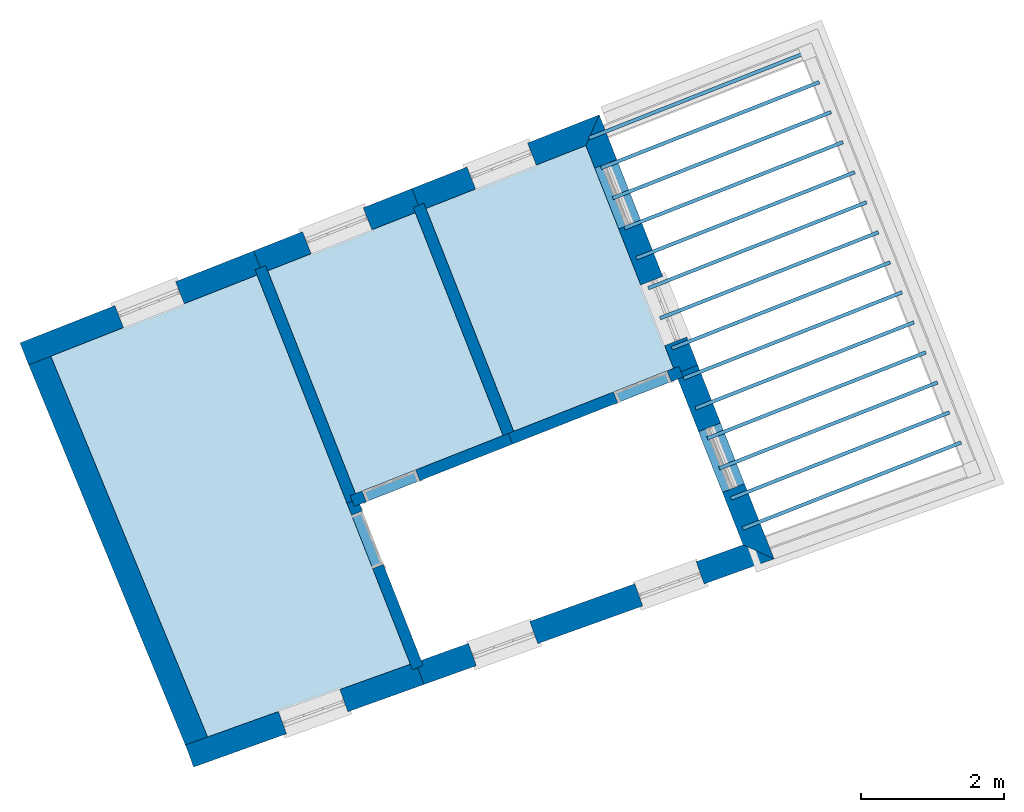
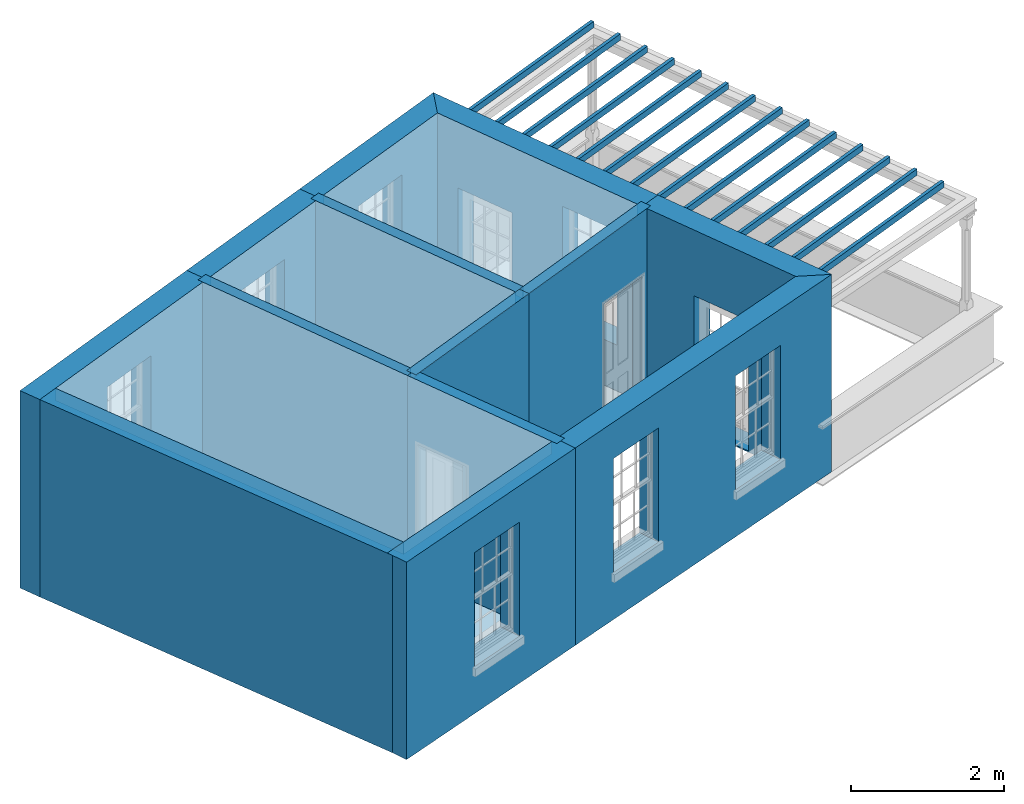
# One storey, part 1 of 8: 20 slabs, 13 walls, 12 openings.
"""IFC2X3 building model written with IfcOpenShell, lengths in metres."""

from ifc_helpers import new_model, si_unit, frame, origin, place, context, subcontext, project, spatial, polyline, outline, extrude, material, layer, layer_set, layer_usage, element, save


model = new_model("IFC2X3")

# Units and contexts
model_context = context("Model", 3, world=origin())
body_context = subcontext(model_context, "Body", "Model", "MODEL_VIEW")
ifc_project = project(units=[si_unit("PLANEANGLEUNIT", "RADIAN"), si_unit("MASSUNIT", "GRAM", prefix="KILO"), si_unit("FORCEUNIT", "NEWTON", prefix="KILO"), si_unit("LENGTHUNIT", "METRE")], contexts=[model_context])

# Site, building, storey
site_placement = place(None, origin())
site = spatial("IfcSite", under=ifc_project, at=site_placement, CompositionType="ELEMENT")
building_placement = place(None, origin())
building = spatial("IfcBuilding", under=site, at=building_placement, Name="Building plot-4", CompositionType="ELEMENT")
storey_placement = place(None, frame((0.0, 0.0, 9.45)))
storey = spatial("IfcBuildingStorey", under=building, at=storey_placement, Name="Floor 2", CompositionType="ELEMENT", Elevation=9.45)

# Slabs
slab_1_placement = place(storey_placement, frame((0.0, 0.0, 2.95)))
element("IfcSlab", 1, at=slab_1_placement, inside=storey, Name="Slab", ObjectType="Slab", PredefinedType="FLOOR", context=body_context, shape_type="SweptSolid", body=[
    extrude(outline(polyline([(47.3779728153786, 51.938533144609), (44.502052775966, 50.8059380590818), (46.6888976082681, 45.4977503358858), (49.5151493068038, 46.5117493116291), (47.3779728153786, 51.938533144609)])), origin(), (0.0, 0.0, 1.0), 0.2),
])
slab_2_placement = place(storey_placement, frame((0.0, 0.0, 2.95)))
element("IfcSlab", 2, at=slab_2_placement, inside=storey, Name="Slab", ObjectType="Slab", PredefinedType="FLOOR", context=body_context, shape_type="SweptSolid", body=[
    extrude(outline(polyline([(50.9563121382697, 49.7590058579402), (53.185811513538, 50.6370275000616), (51.9622563685918, 53.743916100977), (49.7327569933235, 52.8658944588556), (50.9563121382697, 49.7590058579402)])), origin(), (0.0, 0.0, 1.0), 0.2),
])
slab_3_placement = place(storey_placement, frame((0.0, 0.0, 2.65)))
element("IfcSlab", 3, at=slab_3_placement, inside=storey, Name="Slab", ObjectType="Slab", PredefinedType="FLOOR", context=body_context, shape_type="SweptSolid", body=[
    extrude(outline(polyline([(51.9982170837161, 53.8709272302836), (52.0165385048251, 53.8244049181254), (55.0610735768132, 55.0234039907677), (55.0427521557042, 55.0699263029259), (51.9982170837161, 53.8709272302836)])), origin(), (0.0, 0.0, 1.0), 0.1),
])
slab_4_placement = place(storey_placement, frame((0.0, 0.0, 2.65)))
element("IfcSlab", 4, at=slab_4_placement, inside=storey, Name="Slab", ObjectType="Slab", PredefinedType="FLOOR", context=body_context, shape_type="SweptSolid", body=[
    extrude(outline(polyline([(52.1631098736968, 53.4522264208595), (52.1814312948057, 53.4057041087013), (55.2259663667938, 54.6047031813436), (55.2076449456849, 54.6512254935018), (52.1631098736968, 53.4522264208595)])), origin(), (0.0, 0.0, 1.0), 0.1),
])
slab_5_placement = place(storey_placement, frame((0.0, 0.0, 2.65)))
element("IfcSlab", 5, at=slab_5_placement, inside=storey, Name="Slab", ObjectType="Slab", PredefinedType="FLOOR", context=body_context, shape_type="SweptSolid", body=[
    extrude(outline(polyline([(52.3280026636774, 53.0335256114354), (52.3463240847864, 52.9870032992772), (55.3908591567745, 54.1860023719195), (55.3725377356655, 54.2325246840777), (52.3280026636774, 53.0335256114354)])), origin(), (0.0, 0.0, 1.0), 0.1),
])
slab_6_placement = place(storey_placement, frame((0.0, 0.0, 2.65)))
element("IfcSlab", 6, at=slab_6_placement, inside=storey, Name="Slab", ObjectType="Slab", PredefinedType="FLOOR", context=body_context, shape_type="SweptSolid", body=[
    extrude(outline(polyline([(52.4928954536581, 52.6148248020113), (52.511216874767, 52.5683024898531), (55.5557519467552, 53.7673015624954), (55.5374305256462, 53.8138238746536), (52.4928954536581, 52.6148248020113)])), origin(), (0.0, 0.0, 1.0), 0.1),
])
slab_7_placement = place(storey_placement, frame((0.0, 0.0, 2.65)))
element("IfcSlab", 7, at=slab_7_placement, inside=storey, Name="Slab", ObjectType="Slab", PredefinedType="FLOOR", context=body_context, shape_type="SweptSolid", body=[
    extrude(outline(polyline([(52.6577882436387, 52.1961239925872), (52.6761096647477, 52.149601680429), (55.7206447367358, 53.3486007530713), (55.7023233156268, 53.3951230652295), (52.6577882436387, 52.1961239925872)])), origin(), (0.0, 0.0, 1.0), 0.1),
])
slab_8_placement = place(storey_placement, frame((0.0, 0.0, 2.65)))
element("IfcSlab", 8, at=slab_8_placement, inside=storey, Name="Slab", ObjectType="Slab", PredefinedType="FLOOR", context=body_context, shape_type="SweptSolid", body=[
    extrude(outline(polyline([(52.8226810336194, 51.7774231831631), (52.8410024547284, 51.7309008710049), (55.8855375267165, 52.9298999436472), (55.8672161056075, 52.9764222558054), (52.8226810336194, 51.7774231831631)])), origin(), (0.0, 0.0, 1.0), 0.1),
])
slab_9_placement = place(storey_placement, frame((0.0, 0.0, 2.65)))
element("IfcSlab", 9, at=slab_9_placement, inside=storey, Name="Slab", ObjectType="Slab", PredefinedType="FLOOR", context=body_context, shape_type="SweptSolid", body=[
    extrude(outline(polyline([(52.9875738236, 51.358722373739), (53.005895244709, 51.3122000615808), (56.0504303166971, 52.5111991342231), (56.0321088955882, 52.5577214463813), (52.9875738236, 51.358722373739)])), origin(), (0.0, 0.0, 1.0), 0.1),
])
slab_10_placement = place(storey_placement, frame((0.0, 0.0, 2.65)))
element("IfcSlab", 10, at=slab_10_placement, inside=storey, Name="Slab", ObjectType="Slab", PredefinedType="FLOOR", context=body_context, shape_type="SweptSolid", body=[
    extrude(outline(polyline([(53.1524666135807, 50.9400215643149), (53.1707880346897, 50.8934992521567), (56.2153231066778, 52.092498324799), (56.1970016855688, 52.1390206369572), (53.1524666135807, 50.9400215643149)])), origin(), (0.0, 0.0, 1.0), 0.1),
])
slab_11_placement = place(storey_placement, frame((0.0, 0.0, 2.65)))
element("IfcSlab", 11, at=slab_11_placement, inside=storey, Name="Slab", ObjectType="Slab", PredefinedType="FLOOR", context=body_context, shape_type="SweptSolid", body=[
    extrude(outline(polyline([(53.3173594035614, 50.5213207548908), (53.3356808246703, 50.4747984427326), (56.3802158966584, 51.6737975153749), (56.3618944755495, 51.7203198275331), (53.3173594035614, 50.5213207548908)])), origin(), (0.0, 0.0, 1.0), 0.1),
])
slab_12_placement = place(storey_placement, frame((0.0, 0.0, 2.65)))
element("IfcSlab", 12, at=slab_12_placement, inside=storey, Name="Slab", ObjectType="Slab", PredefinedType="FLOOR", context=body_context, shape_type="SweptSolid", body=[
    extrude(outline(polyline([(53.482252193542, 50.1026199454667), (53.500573614651, 50.0560976333085), (56.5451086866391, 51.2550967059508), (56.5267872655301, 51.301619018109), (53.482252193542, 50.1026199454667)])), origin(), (0.0, 0.0, 1.0), 0.1),
])
slab_13_placement = place(storey_placement, frame((0.0, 0.0, 2.65)))
element("IfcSlab", 13, at=slab_13_placement, inside=storey, Name="Slab", ObjectType="Slab", PredefinedType="FLOOR", context=body_context, shape_type="SweptSolid", body=[
    extrude(outline(polyline([(53.6471449835227, 49.6839191360426), (53.6654664046316, 49.6373968238844), (56.7100014766198, 50.8363958965267), (56.6916800555108, 50.8829182086849), (53.6471449835227, 49.6839191360426)])), origin(), (0.0, 0.0, 1.0), 0.1),
])
slab_14_placement = place(storey_placement, frame((0.0, 0.0, 2.65)))
element("IfcSlab", 14, at=slab_14_placement, inside=storey, Name="Slab", ObjectType="Slab", PredefinedType="FLOOR", context=body_context, shape_type="SweptSolid", body=[
    extrude(outline(polyline([(53.8120377735033, 49.2652183266185), (53.8303591946123, 49.2186960144603), (56.8748942666004, 50.4176950871026), (56.8565728454914, 50.4642173992608), (53.8120377735033, 49.2652183266185)])), origin(), (0.0, 0.0, 1.0), 0.1),
])
slab_15_placement = place(storey_placement, frame((0.0, 0.0, 2.65)))
element("IfcSlab", 15, at=slab_15_placement, inside=storey, Name="Slab", ObjectType="Slab", PredefinedType="FLOOR", context=body_context, shape_type="SweptSolid", body=[
    extrude(outline(polyline([(53.976930563484, 48.8465175171944), (53.9952519845929, 48.7999952050362), (57.0397870565811, 49.9989942776785), (57.0214656354721, 50.0455165898367), (53.976930563484, 48.8465175171944)])), origin(), (0.0, 0.0, 1.0), 0.1),
])
slab_16_placement = place(storey_placement, frame((0.0, 0.0, 2.65)))
element("IfcSlab", 16, at=slab_16_placement, inside=storey, Name="Slab", ObjectType="Slab", PredefinedType="FLOOR", context=body_context, shape_type="SweptSolid", body=[
    extrude(outline(polyline([(54.1418233534646, 48.4278167077703), (54.1601447745736, 48.3812943956121), (57.2046798465617, 49.5802934682544), (57.1863584254528, 49.6268157804126), (54.1418233534646, 48.4278167077703)])), origin(), (0.0, 0.0, 1.0), 0.1),
])
slab_17_placement = place(storey_placement, frame((0.0, 0.0, 2.95)))
element("IfcSlab", 17, at=slab_17_placement, inside=storey, Name="Slab", ObjectType="Slab", PredefinedType="FLOOR", context=body_context, shape_type="SweptSolid", body=[
    extrude(outline(polyline([(48.7503993592311, 48.8902730912423), (50.8074407393634, 49.7003773103915), (49.5838855944172, 52.8072659113069), (47.5268442142849, 51.9971616921577), (48.7503993592311, 48.8902730912423)])), origin(), (0.0, 0.0, 1.0), 0.2),
])
slab_18_placement = place(storey_placement, origin())
element("IfcSlab", 18, at=slab_18_placement, inside=storey, Name="Slab", ObjectType="Slab", PredefinedType="FLOOR", context=body_context, shape_type="SweptSolid", body=[
    extrude(outline(polyline([(47.3779728153786, 51.938533144609), (44.502052775966, 50.8059380590818), (46.6888976082681, 45.4977503358858), (49.5151493068038, 46.5117493116291), (47.3779728153786, 51.938533144609)])), origin(), (0.0, 0.0, 1.0), 0.02),
])
slab_19_placement = place(storey_placement, origin())
element("IfcSlab", 19, at=slab_19_placement, inside=storey, Name="Slab", ObjectType="Slab", PredefinedType="FLOOR", context=body_context, shape_type="SweptSolid", body=[
    extrude(outline(polyline([(50.9563121382697, 49.7590058579402), (53.185811513538, 50.6370275000616), (51.9622563685918, 53.743916100977), (49.7327569933235, 52.8658944588556), (50.9563121382697, 49.7590058579402)])), origin(), (0.0, 0.0, 1.0), 0.02),
])
slab_20_placement = place(storey_placement, origin())
element("IfcSlab", 20, at=slab_20_placement, inside=storey, Name="Slab", ObjectType="Slab", PredefinedType="FLOOR", context=body_context, shape_type="SweptSolid", body=[
    extrude(outline(polyline([(48.7503993592311, 48.8902730912423), (50.8074407393634, 49.7003773103915), (49.5838855944172, 52.8072659113069), (47.5268442142849, 51.9971616921577), (48.7503993592311, 48.8902730912423)])), origin(), (0.0, 0.0, 1.0), 0.02),
])

# Wall, opening
ifc_material_1 = material(Name="Masonry")
ifc_layer_1 = layer(ifc_material_1, 0.33, ventilated=False)
ifc_layer_set_1 = layer_set([ifc_layer_1], Name="My Wall")
ifc_layer_usage_1 = layer_usage(ifc_layer_set_1, "AXIS2", "NEGATIVE", 0.08)
wall_1_placement = place(storey_placement, origin())
wall_1 = element("IfcWallStandardCase", 21, at=wall_1_placement, inside=storey, material=ifc_layer_usage_1, Name="exterior", context=body_context, shape_type="SweptSolid", body=[
    extrude(outline(polyline([(46.3816931332496, 45.3875319065881), (46.4931346698559, 45.0769183461649), (49.70423854185, 46.2289940933087), (49.5927970052436, 46.539607653732), (46.3816931332496, 45.3875319065881)])), origin(), (0.0, 0.0, 1.0), 3.15),
])
opening_1_placement = place(storey_placement, frame((0.0, 0.0, 0.75)))
element("IfcOpeningElement", 22, at=opening_1_placement, cuts=wall_1, Name="Opening", ObjectType="Opening", context=body_context, shape_type="SweptSolid", body=[
    extrude(outline(polyline([(47.7880730454297, 45.5415146831305), (48.6446134696272, 45.8488231628631), (48.5331719330208, 46.1594367232864), (47.6766315088233, 45.8521282435537), (47.7880730454297, 45.5415146831305)])), origin(), (0.0, 0.0, 1.0), 1.82),
])

# Wall, openings
wall_2_placement = place(storey_placement, origin())
wall_2 = element("IfcWallStandardCase", 23, at=wall_2_placement, inside=storey, material=ifc_layer_usage_1, Name="exterior", context=body_context, shape_type="SweptSolid", body=[
    extrude(outline(polyline([(49.5927970052436, 46.539607653732), (49.70423854185, 46.2289940933087), (54.5866021542831, 47.9806822762042), (54.1548638616126, 48.176380175453), (49.5927970052436, 46.539607653732)])), origin(), (0.0, 0.0, 1.0), 3.15),
])
opening_2_placement = place(storey_placement, frame((0.0, 0.0, 0.75)))
element("IfcOpeningElement", 24, at=opening_2_placement, cuts=wall_2, Name="Opening", ObjectType="Opening", context=body_context, shape_type="SweptSolid", body=[
    extrude(outline(polyline([(50.4358969684534, 46.4914975693984), (51.2924373926509, 46.7988060491311), (51.1809958560445, 47.1094196095543), (50.3244554318471, 46.8021111298216), (50.4358969684534, 46.4914975693984)])), origin(), (0.0, 0.0, 1.0), 1.82),
])
opening_3_placement = place(storey_placement, frame((0.0, 0.0, 0.75)))
element("IfcOpeningElement", 25, at=opening_3_placement, cuts=wall_2, Name="Opening", ObjectType="Opening", context=body_context, shape_type="SweptSolid", body=[
    extrude(outline(polyline([(52.7557542458578, 47.3238130013103), (53.6122946700553, 47.631121481043), (53.5008531334489, 47.9417350414663), (52.6443127092515, 47.6344265617336), (52.7557542458578, 47.3238130013103)])), origin(), (0.0, 0.0, 1.0), 1.82),
])

# Wall, opening
wall_3_placement = place(storey_placement, origin())
wall_3 = element("IfcWallStandardCase", 26, at=wall_3_placement, inside=storey, material=ifc_layer_usage_1, Name="exterior", context=body_context, shape_type="SweptSolid", body=[
    extrude(outline(polyline([(54.1548638616126, 48.176380175453), (54.5866021542831, 47.9806822762042), (53.5221730475567, 50.6835131799276), (53.2151257873123, 50.5625918006085), (54.1548638616126, 48.176380175453)])), origin(), (0.0, 0.0, 1.0), 3.15),
])
opening_4_placement = place(storey_placement, frame((0.0, 0.0, 0.0199999999999996)))
element("IfcOpeningElement", 27, at=opening_4_placement, cuts=wall_3, Name="Opening", ObjectType="Opening", context=body_context, shape_type="SweptSolid", body=[
    extrude(outline(polyline([(54.1738810813349, 49.0286762323381), (53.8404312171518, 49.8753823136179), (53.5333839569074, 49.7544609342988), (53.8668338210905, 48.9077548530189), (54.1738810813349, 49.0286762323381)])), origin(), (0.0, 0.0, 1.0), 2.08),
])

# Wall, openings
wall_4_placement = place(storey_placement, origin())
wall_4 = element("IfcWallStandardCase", 28, at=wall_4_placement, inside=storey, material=ifc_layer_usage_1, Name="exterior", context=body_context, shape_type="SweptSolid", body=[
    extrude(outline(polyline([(53.2151257873123, 50.5625918006085), (53.5221730475567, 50.6835131799276), (52.148382249517, 54.1718847405405), (51.9622563685918, 53.743916100977), (53.2151257873123, 50.5625918006085)])), origin(), (0.0, 0.0, 1.0), 3.15),
])
opening_5_placement = place(storey_placement, frame((0.0, 0.0, 0.75)))
element("IfcOpeningElement", 29, at=opening_5_placement, cuts=wall_4, Name="Opening", ObjectType="Opening", context=body_context, shape_type="SweptSolid", body=[
    extrude(outline(polyline([(53.3683520565245, 51.0741001392431), (53.0349021923414, 51.9208062205229), (52.7278549320971, 51.7998848412038), (53.0613047962801, 50.953178759924), (53.3683520565245, 51.0741001392431)])), origin(), (0.0, 0.0, 1.0), 1.82),
])
opening_6_placement = place(storey_placement, frame((0.0, 0.0, 0.0199999999999996)))
element("IfcOpeningElement", 30, at=opening_6_placement, cuts=wall_4, Name="Opening", ObjectType="Opening", context=body_context, shape_type="SweptSolid", body=[
    extrude(outline(polyline([(52.727260210277, 52.701980139154), (52.393810346094, 53.5486862204338), (52.0867630858496, 53.4277648411147), (52.4202129500327, 52.5810587598348), (52.727260210277, 52.701980139154)])), origin(), (0.0, 0.0, 1.0), 2.08),
])

# Wall, opening
wall_5_placement = place(storey_placement, origin())
wall_5 = element("IfcWallStandardCase", 31, at=wall_5_placement, inside=storey, material=ifc_layer_usage_1, Name="exterior", context=body_context, shape_type="SweptSolid", body=[
    extrude(outline(polyline([(51.9622563685918, 53.743916100977), (52.148382249517, 54.1718847405405), (49.5373999145512, 53.1436274453256), (49.6583212938703, 52.8365801850812), (51.9622563685918, 53.743916100977)])), origin(), (0.0, 0.0, 1.0), 3.15),
])
opening_7_placement = place(storey_placement, frame((0.0, 0.0, 0.75)))
element("IfcOpeningElement", 32, at=opening_7_placement, cuts=wall_5, Name="Opening", ObjectType="Opening", context=body_context, shape_type="SweptSolid", body=[
    extrude(outline(polyline([(51.1499383422784, 53.7786774722522), (50.3032322609986, 53.4452276080691), (50.4241536403177, 53.1381803478247), (51.2708597215976, 53.4716302120078), (51.1499383422784, 53.7786774722522)])), origin(), (0.0, 0.0, 1.0), 1.82),
])

wall_6_placement = place(storey_placement, origin())
wall_6 = element("IfcWallStandardCase", 33, at=wall_6_placement, inside=storey, material=ifc_layer_usage_1, Name="exterior", context=body_context, shape_type="SweptSolid", body=[
    extrude(outline(polyline([(49.6583212938703, 52.8365801850812), (49.5373999145512, 53.1436274453256), (47.3314871355126, 52.2748946786277), (47.4524085148317, 51.9678474183833), (49.6583212938703, 52.8365801850812)])), origin(), (0.0, 0.0, 1.0), 3.15),
])
opening_8_placement = place(storey_placement, frame((0.0, 0.0, 0.75)))
element("IfcOpeningElement", 34, at=opening_8_placement, cuts=wall_6, Name="Opening", ObjectType="Opening", context=body_context, shape_type="SweptSolid", body=[
    extrude(outline(polyline([(48.8577965656718, 52.8759859940682), (48.011090484392, 52.5425361298851), (48.1320118637111, 52.2354888696407), (48.978717944991, 52.5689387338238), (48.8577965656718, 52.8759859940682)])), origin(), (0.0, 0.0, 1.0), 1.82),
])

wall_7_placement = place(storey_placement, origin())
wall_7 = element("IfcWallStandardCase", 35, at=wall_7_placement, inside=storey, material=ifc_layer_usage_1, Name="exterior", context=body_context, shape_type="SweptSolid", body=[
    extrude(outline(polyline([(47.4524085148317, 51.9678474183833), (47.3314871355126, 52.2748946786277), (44.0729122767796, 50.9916024381462), (44.1938336560988, 50.6845551779018), (47.4524085148317, 51.9678474183833)])), origin(), (0.0, 0.0, 1.0), 3.15),
])
opening_9_placement = place(storey_placement, frame((0.0, 0.0, 0.75)))
element("IfcOpeningElement", 36, at=opening_9_placement, cuts=wall_7, Name="Opening", ObjectType="Opening", context=body_context, shape_type="SweptSolid", body=[
    extrude(outline(polyline([(46.2418585271816, 51.8457770432509), (45.3951524459018, 51.5123271790678), (45.5160738252209, 51.2052799188234), (46.3627799065008, 51.5387297830065), (46.2418585271816, 51.8457770432509)])), origin(), (0.0, 0.0, 1.0), 1.82),
])

# Walls
wall_8_placement = place(storey_placement, origin())
element("IfcWallStandardCase", 37, at=wall_8_placement, inside=storey, material=ifc_layer_usage_1, Name="party", context=body_context, shape_type="SweptSolid", body=[
    extrude(outline(polyline([(44.4710996926754, 50.8810713169569), (44.1659786007411, 50.7553688139714), (46.4128702243124, 45.3014278871074), (46.7179913162467, 45.4271303900929), (44.4710996926754, 50.8810713169569)])), origin(), (0.0, 0.0, 1.0), 3.15),
])
ifc_material_2 = material(Name="Masonry")
ifc_layer_2 = layer(ifc_material_2, 0.16, ventilated=False)
ifc_layer_set_2 = layer_set([ifc_layer_2], Name="My Wall")
ifc_layer_usage_2 = layer_usage(ifc_layer_set_2, "AXIS2", "NEGATIVE", 0.08)
wall_9_placement = place(storey_placement, origin())
element("IfcWallStandardCase", 38, at=wall_9_placement, inside=storey, material=ifc_layer_usage_2, Name="interior", context=body_context, shape_type="SweptSolid", body=[
    extrude(outline(polyline([(48.6308422340991, 48.7572088442405), (48.7797136330055, 48.8158373917891), (47.4975299405106, 52.0715973916108), (47.3486585416042, 52.0129688440622), (48.6308422340991, 48.7572088442405)])), origin(), (0.0, 0.0, 1.0), 3.15),
])

# Wall, opening
wall_10_placement = place(storey_placement, origin())
wall_10 = element("IfcWallStandardCase", 39, at=wall_10_placement, inside=storey, material=ifc_layer_usage_2, Name="interior", context=body_context, shape_type="SweptSolid", body=[
    extrude(outline(polyline([(50.8818764388166, 49.7296915841659), (50.9405049863652, 49.5808201852595), (53.3188757605398, 50.5174703749296), (53.2602472129912, 50.666341773836), (50.8818764388166, 49.7296915841659)])), origin(), (0.0, 0.0, 1.0), 3.15),
])
opening_10_placement = place(storey_placement, frame((0.0, 0.0, 0.0199999999999996)))
element("IfcOpeningElement", 40, at=opening_10_placement, cuts=wall_10, Name="Opening", ObjectType="Opening", context=body_context, shape_type="SweptSolid", body=[
    extrude(outline(polyline([(52.4070384422385, 50.158370521194), (53.1513954367702, 50.4515132589374), (53.0927668892215, 50.6003846578437), (52.3484098946898, 50.3072419201003), (52.4070384422385, 50.158370521194)])), origin(), (0.0, 0.0, 1.0), 2.1),
])

wall_11_placement = place(storey_placement, origin())
wall_11 = element("IfcWallStandardCase", 41, at=wall_11_placement, inside=storey, material=ifc_layer_usage_2, Name="interior", context=body_context, shape_type="SweptSolid", body=[
    extrude(outline(polyline([(48.675963659778, 48.860958817468), (48.7345922073266, 48.7120874185616), (50.9405049863652, 49.5808201852595), (50.8818764388166, 49.7296915841659), (48.675963659778, 48.860958817468)])), origin(), (0.0, 0.0, 1.0), 3.15),
])
opening_11_placement = place(storey_placement, frame((0.0, 0.0, 0.0199999999999996)))
element("IfcOpeningElement", 42, at=opening_11_placement, cuts=wall_11, Name="Opening", ObjectType="Opening", context=body_context, shape_type="SweptSolid", body=[
    extrude(outline(polyline([(48.9020725310963, 48.7780445345539), (49.646429525628, 49.0711872722973), (49.5878009780793, 49.2200586712036), (48.8434439835476, 48.9269159334602), (48.9020725310963, 48.7780445345539)])), origin(), (0.0, 0.0, 1.0), 2.1),
])

# Wall
wall_12_placement = place(storey_placement, origin())
element("IfcWallStandardCase", 43, at=wall_12_placement, inside=storey, material=ifc_layer_usage_2, Name="interior", context=body_context, shape_type="SweptSolid", body=[
    extrude(outline(polyline([(50.8367550131377, 49.6259416109384), (50.9856264120441, 49.684570158487), (49.7034427195492, 52.9403301583087), (49.5545713206428, 52.8817016107601), (50.8367550131377, 49.6259416109384)])), origin(), (0.0, 0.0, 1.0), 3.15),
])

# Wall, opening
wall_13_placement = place(storey_placement, origin())
wall_13 = element("IfcWallStandardCase", 44, at=wall_13_placement, inside=storey, material=ifc_layer_usage_2, Name="interior", context=body_context, shape_type="SweptSolid", body=[
    extrude(outline(polyline([(48.7797136330055, 48.8158373917891), (48.6308422340991, 48.7572088442405), (49.5453774358768, 46.4349931228854), (49.6942488347832, 46.493621670434), (48.7797136330055, 48.8158373917891)])), origin(), (0.0, 0.0, 1.0), 3.15),
])
opening_12_placement = place(storey_placement, frame((0.0, 0.0, 0.0199999999999996)))
element("IfcOpeningElement", 45, at=opening_12_placement, cuts=wall_13, Name="Opening", ObjectType="Opening", context=body_context, shape_type="SweptSolid", body=[
    extrude(outline(polyline([(48.6967993500914, 48.5897285204708), (48.9899420878348, 47.8453715259391), (49.1388134867411, 47.9040000734878), (48.8456707489977, 48.6483570680195), (48.6967993500914, 48.5897285204708)])), origin(), (0.0, 0.0, 1.0), 2.1),
])

save(model, "model.ifc")
